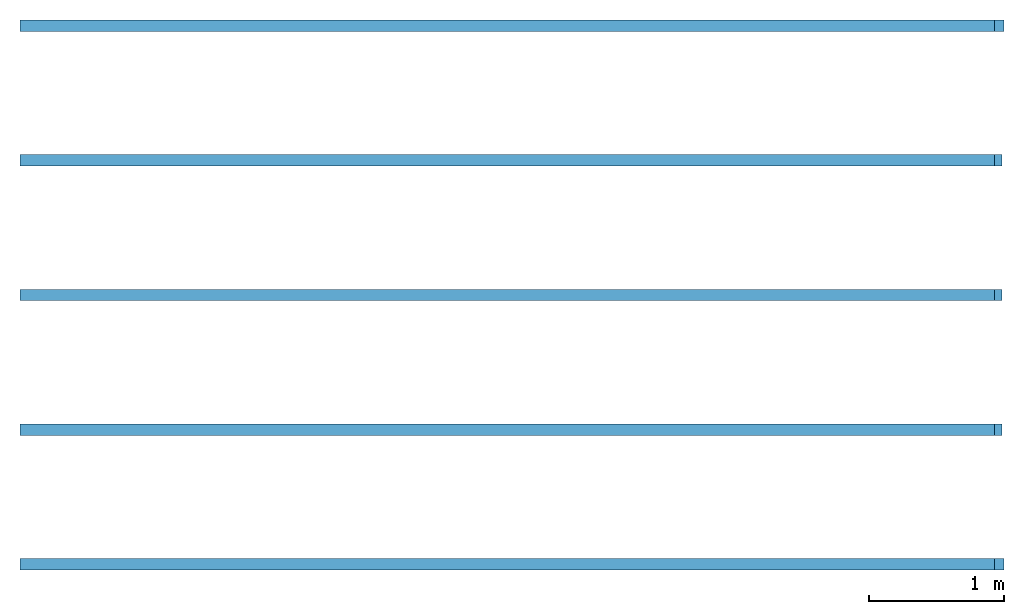
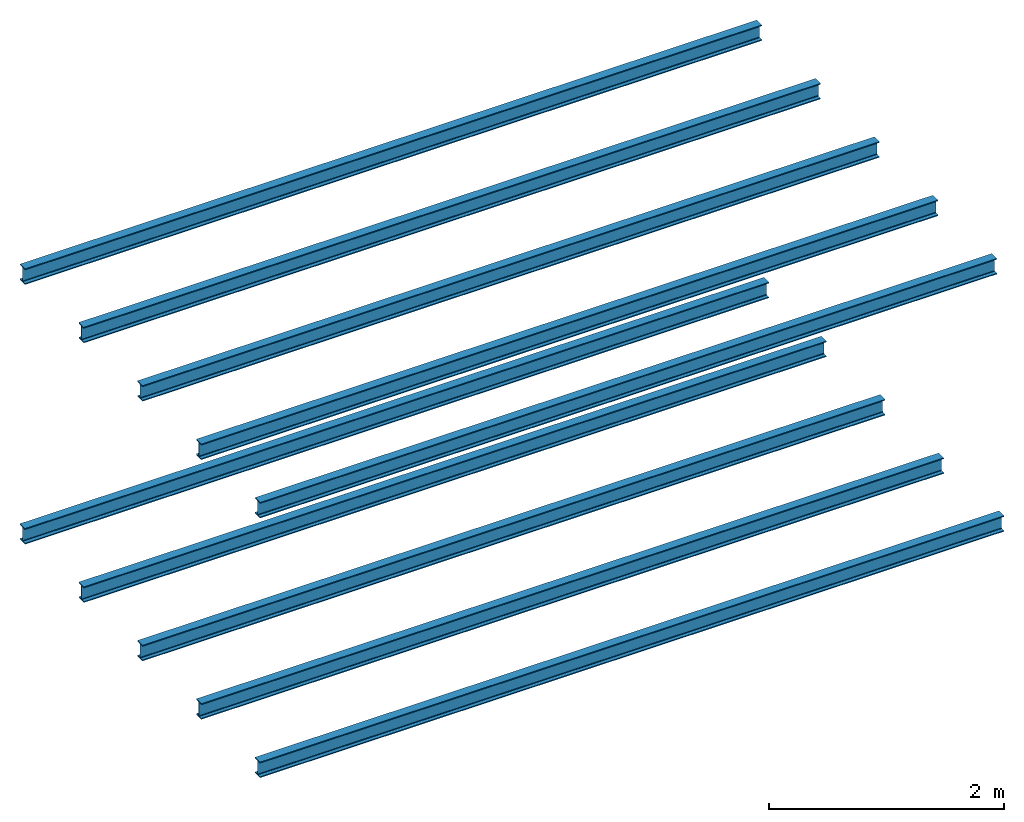
# One storey: 10 beams, 2 elements without a shape of their own.
"""IFC2X3 building model written with IfcOpenShell, lengths in millimetres."""

from ifc_helpers import new_model, entity, si_unit, converted_unit, derived_unit, direction, frame, frame_2d, origin, place, context, subcontext, project, spatial, i_section, extrude, material, element, aggregate, save


model = new_model("IFC2X3")

# Units and contexts
model_context = context("Model", 3, precision=0.01, world=origin(), true_north=direction((6.12303176911189e-17, 1.0)))
body_context = subcontext(model_context, "Body", "Model", "MODEL_VIEW")
ifc_project = project(units=[si_unit("LENGTHUNIT", "METRE", prefix="MILLI"), si_unit("AREAUNIT", "SQUARE_METRE"), si_unit("VOLUMEUNIT", "CUBIC_METRE"), converted_unit("PLANEANGLEUNIT", "DEGREE", entity("IfcRatioMeasure", 0.0174532925199433), si_unit("PLANEANGLEUNIT", "RADIAN"), dimensions=[0, 0, 0, 0, 0, 0, 0]), si_unit("MASSUNIT", "GRAM", prefix="KILO"), si_unit("TIMEUNIT", "SECOND"), si_unit("FREQUENCYUNIT", "HERTZ"), si_unit("THERMODYNAMICTEMPERATUREUNIT", "DEGREE_CELSIUS"), derived_unit("THERMALTRANSMITTANCEUNIT", [(si_unit("MASSUNIT", "GRAM", prefix="KILO"), 1), (si_unit("THERMODYNAMICTEMPERATUREUNIT", "KELVIN"), -1), (si_unit("TIMEUNIT", "SECOND"), -3)]), derived_unit("VOLUMETRICFLOWRATEUNIT", [(si_unit("LENGTHUNIT", "METRE"), 3), (si_unit("TIMEUNIT", "SECOND"), -1)]), si_unit("ELECTRICCURRENTUNIT", "AMPERE"), si_unit("ELECTRICVOLTAGEUNIT", "VOLT"), si_unit("POWERUNIT", "WATT"), si_unit("FORCEUNIT", "NEWTON", prefix="KILO"), si_unit("ILLUMINANCEUNIT", "LUX"), si_unit("LUMINOUSFLUXUNIT", "LUMEN"), si_unit("LUMINOUSINTENSITYUNIT", "CANDELA"), derived_unit("USERDEFINED", [(si_unit("MASSUNIT", "GRAM", prefix="KILO"), -1), (si_unit("LENGTHUNIT", "METRE"), -2), (si_unit("TIMEUNIT", "SECOND"), 3), (si_unit("LUMINOUSFLUXUNIT", "LUMEN"), 1)]), derived_unit("LINEARVELOCITYUNIT", [(si_unit("LENGTHUNIT", "METRE"), 1), (si_unit("TIMEUNIT", "SECOND"), -1)]), si_unit("PRESSUREUNIT", "PASCAL"), derived_unit("USERDEFINED", [(si_unit("LENGTHUNIT", "METRE"), -2), (si_unit("MASSUNIT", "GRAM", prefix="KILO"), 1), (si_unit("TIMEUNIT", "SECOND"), -2)])], contexts=[model_context])

# Site, building, storey
site_placement = place(None, origin())
site = spatial("IfcSite", under=ifc_project, at=site_placement, CompositionType="ELEMENT")
building_placement = place(site_placement, origin())
building = spatial("IfcBuilding", under=site, at=building_placement, CompositionType="ELEMENT")
storey_placement = place(building_placement, frame((0.0, 0.0, 2800.0)))
storey = spatial("IfcBuildingStorey", under=building, at=storey_placement, CompositionType="ELEMENT", Elevation=2800.0)

# Assembly, beams
assembly_1_placement = place(storey_placement, origin())
assembly_1 = element("IfcElementAssembly", 1, at=assembly_1_placement, inside=storey, Name="konstrukce", ObjectType="konstrukce", AssemblyPlace="NOTDEFINED", PredefinedType="BEAM_GRID")
ifc_material = material(Name="ocel 43-275")
beam_1_placement = place(assembly_1_placement, frame((-4566.75586013303, -1085.67462444171, -2800.0), z_axis=(0.0, 0.0, 1.0), x_axis=(-1.0, 0.0, 0.0)))
beam_1 = element("IfcBeam", 2, at=beam_1_placement, material=ifc_material, context=body_context, shape_type="SweptSolid", body=[
    extrude(i_section(OverallWidth=85.0000000000002, OverallDepth=163.4, WebThickness=5.99999999999999, FlangeThickness=10.2000000000009, FilletRadius=8.90000000000028, at=frame_2d((0.0, 1.35003119794419e-13), x_axis=(0.0, 1.0))), frame((0.0, 0.0, 2671.29999999999), z_axis=(1.0, 0.0, 0.0), x_axis=(0.0, 0.0, -1.0)), (0.0, 0.0, 1.0), 7309.0),
])
beam_2_placement = place(assembly_1_placement, frame((-4525.35452428205, -85.6746244417148, -2800.0), z_axis=(0.0, 0.0, 1.0), x_axis=(-1.0, 0.0, 0.0)))
beam_2 = element("IfcBeam", 3, at=beam_2_placement, material=ifc_material, context=body_context, shape_type="SweptSolid", body=[
    extrude(i_section(OverallWidth=85.0000000000002, OverallDepth=163.4, WebThickness=6.00000000000007, FlangeThickness=10.2000000000009, FilletRadius=8.90000000000028, at=frame_2d((0.0, 5.32907051820075e-14), x_axis=(0.0, 1.0))), frame((55.2006679254933, 0.0, 2671.29999999999), z_axis=(1.0, 0.0, 0.0), x_axis=(0.0, 0.0, -1.0)), (0.0, 0.0, 1.0), 7295.2),
])
beam_3_placement = place(assembly_1_placement, frame((-4525.35452428204, 914.325375558285, -2800.0), z_axis=(0.0, 0.0, 1.0), x_axis=(-1.0, 0.0, 0.0)))
beam_3 = element("IfcBeam", 4, at=beam_3_placement, material=ifc_material, context=body_context, shape_type="SweptSolid", body=[
    extrude(i_section(OverallWidth=85.0000000000002, OverallDepth=163.4, WebThickness=5.99999999999999, FlangeThickness=10.2000000000009, FilletRadius=8.90000000000028, at=frame_2d((5.40012479177676e-13, 1.35003119794419e-13), x_axis=(0.0, 1.0))), frame((55.2006679254949, 0.0, 2671.29999999999), z_axis=(1.0, 0.0, 0.0), x_axis=(0.0, 0.0, -1.0)), (0.0, 0.0, 1.0), 7295.2),
])
beam_4_placement = place(assembly_1_placement, frame((-4525.35452428204, 1914.32537555829, -2800.0), z_axis=(0.0, 0.0, 1.0), x_axis=(-1.0, 0.0, 0.0)))
beam_4 = element("IfcBeam", 5, at=beam_4_placement, material=ifc_material, context=body_context, shape_type="SweptSolid", body=[
    extrude(i_section(OverallWidth=85.0000000000002, OverallDepth=163.4, WebThickness=6.00000000000026, FlangeThickness=10.2000000000009, FilletRadius=8.89999999999998, at=frame_2d((0.0, -2.70006239588838e-13), x_axis=(0.0, 1.0))), frame((55.2006679254965, 0.0, 2671.29999999999), z_axis=(1.0, 0.0, 0.0), x_axis=(0.0, 0.0, -1.0)), (0.0, 0.0, 1.0), 7295.2),
])
beam_5_placement = place(assembly_1_placement, frame((-4566.75586013303, 2914.32537555829, -2800.0), z_axis=(0.0, 0.0, 1.0), x_axis=(-1.0, 0.0, 0.0)))
beam_5 = element("IfcBeam", 6, at=beam_5_placement, material=ifc_material, context=body_context, shape_type="SweptSolid", body=[
    extrude(i_section(OverallWidth=85.0000000000002, OverallDepth=163.4, WebThickness=6.00000000000026, FlangeThickness=10.2000000000009, FilletRadius=8.90000000000043, at=frame_2d((0.0, 2.70006239588838e-13), x_axis=(0.0, 1.0))), frame((0.0, 0.0, 2671.29999999999), z_axis=(1.0, 0.0, 0.0), x_axis=(0.0, 0.0, -1.0)), (0.0, 0.0, 1.0), 7309.0),
])
aggregate(assembly_1, [beam_1, beam_2, beam_3, beam_4, beam_5])

assembly_2_placement = place(storey_placement, origin())
assembly_2 = element("IfcElementAssembly", 7, at=assembly_2_placement, inside=storey, Name="konstrukce", ObjectType="konstrukce", AssemblyPlace="NOTDEFINED", PredefinedType="BEAM_GRID")
beam_6_placement = place(assembly_2_placement, frame((-11875.755860133, 2914.32537555828, 0.0)))
beam_6 = element("IfcBeam", 8, at=beam_6_placement, material=ifc_material, context=body_context, shape_type="SweptSolid", body=[
    extrude(i_section(OverallWidth=85.0000000000002, OverallDepth=163.4, WebThickness=6.00000000000026, FlangeThickness=10.1999999999998, FilletRadius=8.90000000000009, at=frame_2d((1.08002495835535e-12, -5.40012479177676e-13), x_axis=(0.0, 1.0))), frame((0.0, 0.0, 2568.29999999999), z_axis=(1.0, 0.0, 0.0), x_axis=(0.0, 0.0, -1.0)), (0.0, 0.0, 1.0), 7239.0),
])
beam_7_placement = place(assembly_2_placement, frame((-11875.755860133, 1914.32537555828, 0.0)))
beam_7 = element("IfcBeam", 9, at=beam_7_placement, material=ifc_material, context=body_context, shape_type="SweptSolid", body=[
    extrude(i_section(OverallWidth=85.0000000000002, OverallDepth=163.4, WebThickness=6.00000000000026, FlangeThickness=10.1999999999998, FilletRadius=8.89999999999965, at=frame_2d((1.08002495835535e-12, -5.40012479177676e-13), x_axis=(0.0, 1.0))), frame((0.0, 0.0, 2568.29999999999), z_axis=(1.0, 0.0, 0.0), x_axis=(0.0, 0.0, -1.0)), (0.0, 0.0, 1.0), 7239.0),
])
beam_8_placement = place(assembly_2_placement, frame((-11875.755860133, 914.325375558284, 0.0)))
beam_8 = element("IfcBeam", 10, at=beam_8_placement, material=ifc_material, context=body_context, shape_type="SweptSolid", body=[
    extrude(i_section(OverallWidth=85.0000000000002, OverallDepth=163.4, WebThickness=5.99999999999999, FlangeThickness=10.1999999999998, FilletRadius=8.89999999999991, at=frame_2d((1.08002495835535e-12, 4.05009359383257e-13), x_axis=(0.0, 1.0))), frame((0.0, 0.0, 2568.29999999999), z_axis=(1.0, 0.0, 0.0), x_axis=(0.0, 0.0, -1.0)), (0.0, 0.0, 1.0), 7239.0),
])
beam_9_placement = place(assembly_2_placement, frame((-11875.755860133, -85.6746244417164, 0.0)))
beam_9 = element("IfcBeam", 11, at=beam_9_placement, material=ifc_material, context=body_context, shape_type="SweptSolid", body=[
    extrude(i_section(OverallWidth=85.0000000000002, OverallDepth=163.4, WebThickness=6.00000000000007, FlangeThickness=10.1999999999998, FilletRadius=8.89999999999993, at=frame_2d((1.08002495835535e-12, 5.32907051820075e-14), x_axis=(0.0, 1.0))), frame((0.0, 0.0, 2568.29999999999), z_axis=(1.0, 0.0, 0.0), x_axis=(0.0, 0.0, -1.0)), (0.0, 0.0, 1.0), 7239.0),
])
beam_10_placement = place(assembly_2_placement, frame((-11875.755860133, -1085.67462444172, 0.0)))
beam_10 = element("IfcBeam", 12, at=beam_10_placement, material=ifc_material, context=body_context, shape_type="SweptSolid", body=[
    extrude(i_section(OverallWidth=85.0000000000002, OverallDepth=163.4, WebThickness=5.99999999999999, FlangeThickness=10.1999999999998, FilletRadius=8.89999999999991, at=frame_2d((1.08002495835535e-12, 4.05009359383257e-13), x_axis=(0.0, 1.0))), frame((0.0, 0.0, 2568.29999999999), z_axis=(1.0, 0.0, 0.0), x_axis=(0.0, 0.0, -1.0)), (0.0, 0.0, 1.0), 7239.0),
])
aggregate(assembly_2, [beam_6, beam_7, beam_8, beam_9, beam_10])

save(model, "model.ifc")
